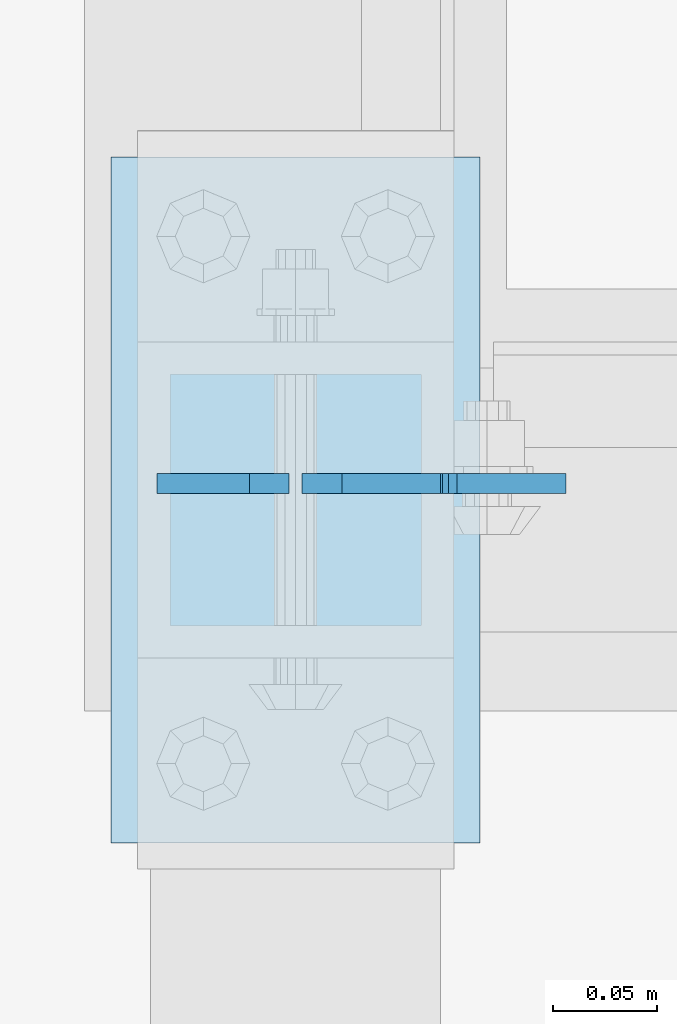
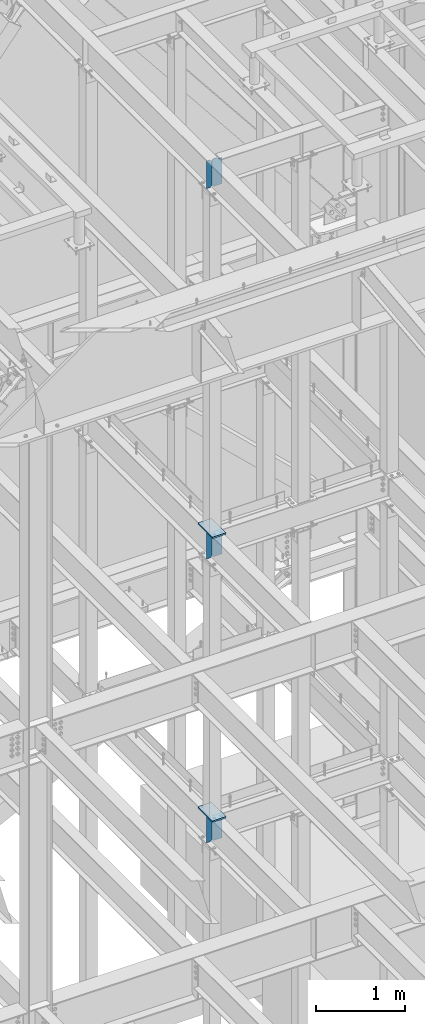
# One storey, part 1078 of 1179: 8 plates, 5 elements without a shape of their own.
"""IFC2X3 building model written with IfcOpenShell, lengths in millimetres."""

from ifc_helpers import new_model, si_unit, frame, origin_with_axes, place, context, subcontext, project, spatial, faceted_brep, material, type_object, element, aggregate, save


model = new_model("IFC2X3")

# Units and contexts
model_context = context("Model", 3, precision=1e-05, world=origin_with_axes())
body_context = subcontext(model_context, "Body", "Model", "MODEL_VIEW")
ifc_project = project(units=[si_unit("LENGTHUNIT", "METRE", prefix="MILLI"), si_unit("AREAUNIT", "SQUARE_METRE"), si_unit("VOLUMEUNIT", "CUBIC_METRE"), si_unit("MASSUNIT", "GRAM", prefix="KILO"), si_unit("TIMEUNIT", "SECOND"), si_unit("PLANEANGLEUNIT", "RADIAN"), si_unit("SOLIDANGLEUNIT", "STERADIAN"), si_unit("THERMODYNAMICTEMPERATUREUNIT", "DEGREE_CELSIUS"), si_unit("LUMINOUSINTENSITYUNIT", "LUMEN")], contexts=[model_context])

# Site, building, storey
site_placement = place(None, origin_with_axes())
site = spatial("IfcSite", under=ifc_project, at=site_placement, CompositionType="ELEMENT")
building_placement = place(site_placement, origin_with_axes())
building = spatial("IfcBuilding", under=site, at=building_placement, Name="Undefined", CompositionType="ELEMENT")
storey_placement = place(building_placement, origin_with_axes())
storey = spatial("IfcBuildingStorey", under=building, at=storey_placement, Name="Undefined", CompositionType="ELEMENT", Elevation=0.0)

# Assembly, plate
assembly_1_placement = place(storey_placement, origin_with_axes())
assembly_1 = element("IfcElementAssembly", 1, at=assembly_1_placement, inside=storey, Name="BEAM", AssemblyPlace="NOTDEFINED", PredefinedType="RIGID_FRAME")
ifc_material = material(Name="STEEL/A36")
plate_type_1 = type_object("IfcPlateType", PredefinedType="NOTDEFINED")
plate_1_placement = place(assembly_1_placement, frame((11877.675, 36647.4379999161, 7623.175), z_axis=(0.0, 0.0, 1.0), x_axis=(1.0, 0.0, 0.0)))
plate_1 = element("IfcPlate", 2, at=plate_1_placement, type_object=plate_type_1, material=ifc_material, Name="PLATE", context=body_context, shape_type="Brep", body=[
    faceted_brep([(66.6749998164378, -4.76249999999709, 377.825), (66.6749999434469, -4.76249999999709, 371.474999553748), (66.6749999434469, 4.76249999999709, 371.474999553748), (66.6749998164378, 4.76249999999709, 377.825), (67.641729938794, -4.76249999999709, 366.614920114053), (67.641729938794, 4.76249999999709, 366.614920114053), (70.394743855788, -4.76249999999709, 362.494743732281), (70.394743855788, 4.76249999999709, 362.494743732281), (74.5149202922948, -4.76249999999709, 359.741729897201), (74.5149202922948, 4.76249999999709, 359.741729897201), (79.3749997512095, -4.76249999999709, 358.774999998475), (79.3749997512095, 4.76249999999709, 358.774999998475), (127.000000004868, -4.76249999999709, 358.774999992755), (127.0, 4.76249999999709, 358.774999992755), (0.0, -4.76249999999709, 358.775000762939), (19.0499992370605, -4.76249999999709, 377.825), (19.0499992370605, 4.76249999999709, 377.825), (0.0, 4.76249999999709, 358.775000762939), (0.0, -4.76250000000073, 19.0499992370605), (0.0, 4.76250000000073, 19.0499992370605), (19.0499992370605, -4.76250000000073, 0.0), (19.0499992370605, 4.76250000000073, 0.0), (127.0, -4.76250000000073, 0.0), (127.0, 4.76250000000073, 0.0)], [[[0, 1, 2, 3]], [[4, 5, 2, 1]], [[6, 7, 5, 4]], [[8, 9, 7, 6]], [[10, 11, 9, 8]], [[12, 13, 11, 10]], [[14, 15, 16, 17]], [[18, 14, 17, 19]], [[20, 18, 19, 21]], [[22, 20, 21, 23]], [[8, 6, 4, 1, 0, 15, 14, 18, 20, 22, 12, 10]], [[16, 15, 0, 3]], [[23, 21, 19, 17, 16, 3, 2, 5, 7, 9, 11, 13]], [[22, 23, 13, 12]]]),
])

assembly_2_placement = place(storey_placement, origin_with_axes())
assembly_2 = element("IfcElementAssembly", 3, at=assembly_2_placement, inside=storey, Name="BEAM", AssemblyPlace="NOTDEFINED", PredefinedType="RIGID_FRAME")
plate_2_placement = place(assembly_2_placement, frame((11877.6751123327, 36647.4379707852, 3711.575), z_axis=(0.0, 0.0, 1.0), x_axis=(1.0, 0.0, 0.0)))
plate_2 = element("IfcPlate", 4, at=plate_2_placement, type_object=plate_type_1, material=ifc_material, Name="PLATE", context=body_context, shape_type="Brep", body=[
    faceted_brep([(66.6756118831599, -4.76249999999709, 377.825), (66.6754110961774, -4.76249999999709, 371.475401414235), (66.6754122391831, 4.76249999999709, 371.4754014142), (66.675613026182, 4.76249999999709, 377.825), (67.6420257521768, -4.76249999999709, 366.615198568966), (67.6420268951824, 4.76249999999709, 366.615198568931), (70.3950129291698, -4.76249999999709, 362.494885814615), (70.3950140721736, 4.76249999999709, 362.49488581458), (74.5152386277114, -4.76249999999709, 359.741768348284), (74.515239770717, 4.76249999999709, 359.741768348249), (79.3754109046859, -4.76249999999709, 358.775000005575), (79.3754120476915, 4.76249999999709, 358.775000005541), (127.000000004868, -4.76249999999709, 358.774999992755), (127.0, 4.76249999999709, 358.774999992755), (0.0, -4.76249999999709, 358.775000762939), (19.0499992370605, -4.76249999999709, 377.825), (19.0499992370605, 4.76249999999709, 377.825), (0.0, 4.76249999999709, 358.775000762939), (0.0, -4.76250000000073, 19.0499992370605), (0.0, 4.76250000000073, 19.0499992370605), (19.0499992370605, -4.76250000000073, 0.0), (19.0499992370605, 4.76250000000073, 0.0), (127.0, -4.76250000000073, 0.0), (127.0, 4.76250000000073, 0.0)], [[[0, 1, 2, 3]], [[4, 5, 2, 1]], [[6, 7, 5, 4]], [[8, 9, 7, 6]], [[10, 11, 9, 8]], [[12, 13, 11, 10]], [[14, 15, 16, 17]], [[18, 14, 17, 19]], [[20, 18, 19, 21]], [[22, 20, 21, 23]], [[8, 6, 4, 1, 0, 15, 14, 18, 20, 22, 12, 10]], [[16, 15, 0, 3]], [[23, 21, 19, 17, 16, 3, 2, 5, 7, 9, 11, 13]], [[22, 23, 13, 12]]]),
])

assembly_3_placement = place(storey_placement, origin_with_axes())
assembly_3 = element("IfcElementAssembly", 5, at=assembly_3_placement, inside=storey, Name="BEAM", AssemblyPlace="NOTDEFINED", PredefinedType="RIGID_FRAME")
plate_3_placement = place(assembly_3_placement, frame((11877.675, 36647.4379999161, 12728.575), z_axis=(0.0, 0.0, 1.0), x_axis=(1.0, 0.0, 0.0)))
plate_3 = element("IfcPlate", 6, at=plate_3_placement, type_object=plate_type_1, material=ifc_material, Name="PLATE", context=body_context, shape_type="Brep", body=[
    faceted_brep([(66.6749998164378, -4.76249999999709, 377.825), (66.6749999434469, -4.76249999999709, 371.474999553748), (66.6749999434469, 4.76249999999709, 371.474999553748), (66.6749998164378, 4.76249999999709, 377.825), (67.641729938794, -4.76249999999709, 366.614920114053), (67.641729938794, 4.76249999999709, 366.614920114053), (70.394743855788, -4.76249999999709, 362.494743732281), (70.394743855788, 4.76249999999709, 362.494743732281), (74.5149202922948, -4.76249999999709, 359.741729897201), (74.5149202922948, 4.76249999999709, 359.741729897201), (79.3749997512095, -4.76249999999709, 358.774999998475), (79.3749997512095, 4.76249999999709, 358.774999998475), (127.000000004868, -4.76249999999709, 358.774999992755), (127.0, 4.76249999999709, 358.774999992755), (0.0, -4.76249999999709, 358.775000762939), (19.0499992370605, -4.76249999999709, 377.825), (19.0499992370605, 4.76249999999709, 377.825), (0.0, 4.76249999999709, 358.775000762939), (0.0, -4.76250000000073, 19.0499992370605), (0.0, 4.76250000000073, 19.0499992370605), (19.0499992370605, -4.76250000000073, 0.0), (19.0499992370605, 4.76250000000073, 0.0), (127.0, -4.76250000000073, 0.0), (127.0, 4.76250000000073, 0.0)], [[[0, 1, 2, 3]], [[4, 5, 2, 1]], [[6, 7, 5, 4]], [[8, 9, 7, 6]], [[10, 11, 9, 8]], [[12, 13, 11, 10]], [[14, 15, 16, 17]], [[18, 14, 17, 19]], [[20, 18, 19, 21]], [[22, 20, 21, 23]], [[8, 6, 4, 1, 0, 15, 14, 18, 20, 22, 12, 10]], [[16, 15, 0, 3]], [[23, 21, 19, 17, 16, 3, 2, 5, 7, 9, 11, 13]], [[22, 23, 13, 12]]]),
])

assembly_4_placement = place(storey_placement, origin_with_axes())
assembly_4 = element("IfcElementAssembly", 7, at=assembly_4_placement, inside=storey, Name="COLUMN", AssemblyPlace="NOTDEFINED", PredefinedType="RIGID_FRAME")
plate_type_2 = type_object("IfcPlateType", PredefinedType="NOTDEFINED")
plate_4_placement = place(assembly_4_placement, frame((11785.6, 36474.4, 8023.225), z_axis=(0.0, 1.0, 0.0), x_axis=(1.0, 0.0, 0.0)))
plate_4 = element("IfcPlate", 8, at=plate_4_placement, type_object=plate_type_2, material=ifc_material, Name="PLATE", context=body_context, shape_type="Brep", body=[
    faceted_brep([(0.0, -9.52499999999964, 0.0), (0.0, -9.52499999999964, 330.200012207031), (0.0, 9.52499999999964, 330.200012207031), (0.0, 9.52499999999964, 0.0), (177.800003051758, -9.52499999999964, 330.200012207031), (177.800003051758, 9.52499999999964, 330.200012207031), (177.800003051758, -9.52499999999964, 0.0), (177.800003051758, 9.52499999999964, 0.0)], [[[0, 1, 2, 3]], [[1, 4, 5, 2]], [[4, 6, 7, 5]], [[6, 0, 3, 7]], [[5, 7, 3, 2]], [[6, 4, 1, 0]]]),
])
aggregate(assembly_4, [plate_4])

assembly_5_placement = place(storey_placement, origin_with_axes())
assembly_5 = element("IfcElementAssembly", 9, at=assembly_5_placement, inside=storey, Name="COLUMN", AssemblyPlace="NOTDEFINED", PredefinedType="RIGID_FRAME")
plate_5_placement = place(assembly_5_placement, frame((11785.5999999996, 36474.4, 4111.625), z_axis=(0.0, 1.0, 0.0), x_axis=(1.0, 0.0, 0.0)))
plate_5 = element("IfcPlate", 10, at=plate_5_placement, type_object=plate_type_2, material=ifc_material, Name="PLATE", context=body_context, shape_type="Brep", body=[
    faceted_brep([(0.0, -9.52499999999964, 0.0), (0.0, -9.52499999999964, 330.200012207031), (0.0, 9.52499999999964, 330.200012207031), (0.0, 9.52499999999964, 0.0), (177.800003051758, -9.52499999999964, 330.200012207031), (177.800003051758, 9.52499999999964, 330.200012207031), (177.800003051758, -9.52499999999964, 0.0), (177.800003051758, 9.52499999999964, 0.0)], [[[0, 1, 2, 3]], [[1, 4, 5, 2]], [[4, 6, 7, 5]], [[6, 0, 3, 7]], [[5, 7, 3, 2]], [[6, 4, 1, 0]]]),
])
aggregate(assembly_5, [plate_5])

# Plate
plate_type_3 = type_object("IfcPlateType", PredefinedType="NOTDEFINED")
plate_6_placement = place(assembly_1_placement, frame((11871.325, 36647.4379999161, 7623.175), z_axis=(0.0, 0.0, 1.0), x_axis=(-1.0, 0.0, 0.0)))
plate_6 = element("IfcPlate", 11, at=plate_6_placement, type_object=plate_type_3, material=ifc_material, Name="PLATE", context=body_context, shape_type="Brep", body=[
    faceted_brep([(0.0, -4.76250000000073, 19.0499992370605), (0.0, -4.76249999999709, 358.775000762939), (0.0, 4.76249999999709, 358.775000762939), (0.0, 4.76250000000073, 19.0499992370605), (19.0499992370605, -4.76249999999709, 377.825), (19.0499992370605, 4.76249999999709, 377.825), (63.5, -4.76250000000073, 377.825012207031), (63.5, 4.76250000000073, 377.825012207031), (63.5, -4.76250000000073, 0.0), (63.5, 4.76250000000073, 0.0), (19.0499992370605, -4.76250000000073, 0.0), (19.0499992370605, 4.76250000000073, 0.0)], [[[0, 1, 2, 3]], [[1, 4, 5, 2]], [[4, 6, 7, 5]], [[6, 8, 9, 7]], [[8, 10, 11, 9]], [[10, 0, 3, 11]], [[5, 7, 9, 11, 3, 2]], [[10, 8, 6, 4, 1, 0]]]),
])

aggregate(assembly_1, [plate_6, plate_1])

plate_7_placement = place(assembly_2_placement, frame((11871.3251122137, 36647.4379706265, 3711.575), z_axis=(0.0, 0.0, 1.0), x_axis=(-1.0, 0.0, 0.0)))
plate_7 = element("IfcPlate", 12, at=plate_7_placement, type_object=plate_type_3, material=ifc_material, Name="PLATE", context=body_context, shape_type="Brep", body=[
    faceted_brep([(0.0, -4.76250000000073, 19.0499992370605), (0.0, -4.76249999999709, 358.775000762939), (0.0, 4.76249999999709, 358.775000762939), (0.0, 4.76250000000073, 19.0499992370605), (19.0499992370605, -4.76249999999709, 377.825), (19.0499992370605, 4.76249999999709, 377.825), (63.5, -4.76250000000073, 377.825012207031), (63.5, 4.76250000000073, 377.825012207031), (63.5, -4.76250000000073, 0.0), (63.5, 4.76250000000073, 0.0), (19.0499992370605, -4.76250000000073, 0.0), (19.0499992370605, 4.76250000000073, 0.0)], [[[0, 1, 2, 3]], [[1, 4, 5, 2]], [[4, 6, 7, 5]], [[6, 8, 9, 7]], [[8, 10, 11, 9]], [[10, 0, 3, 11]], [[5, 7, 9, 11, 3, 2]], [[10, 8, 6, 4, 1, 0]]]),
])

aggregate(assembly_2, [plate_7, plate_2])

plate_8_placement = place(assembly_3_placement, frame((11871.325, 36647.4379999161, 12728.575), z_axis=(0.0, 0.0, 1.0), x_axis=(-1.0, 0.0, 0.0)))
plate_8 = element("IfcPlate", 13, at=plate_8_placement, type_object=plate_type_3, material=ifc_material, Name="PLATE", context=body_context, shape_type="Brep", body=[
    faceted_brep([(0.0, -4.76250000000073, 19.0499992370605), (0.0, -4.76249999999709, 358.775000762939), (0.0, 4.76249999999709, 358.775000762939), (0.0, 4.76250000000073, 19.0499992370605), (19.0499992370605, -4.76249999999709, 377.825), (19.0499992370605, 4.76249999999709, 377.825), (63.5, -4.76250000000073, 377.825012207031), (63.5, 4.76250000000073, 377.825012207031), (63.5, -4.76250000000073, 0.0), (63.5, 4.76250000000073, 0.0), (19.0499992370605, -4.76250000000073, 0.0), (19.0499992370605, 4.76250000000073, 0.0)], [[[0, 1, 2, 3]], [[1, 4, 5, 2]], [[4, 6, 7, 5]], [[6, 8, 9, 7]], [[8, 10, 11, 9]], [[10, 0, 3, 11]], [[5, 7, 9, 11, 3, 2]], [[10, 8, 6, 4, 1, 0]]]),
])

aggregate(assembly_3, [plate_8, plate_3])

save(model, "model.ifc")
